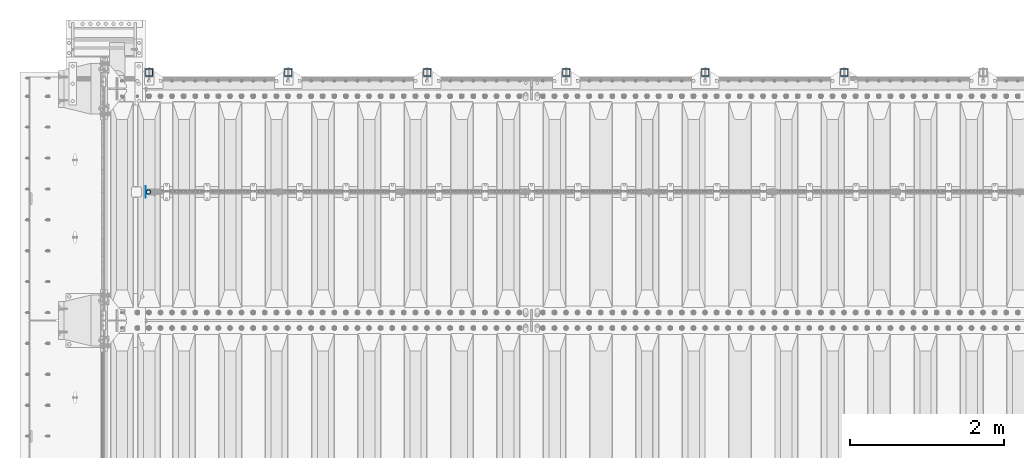
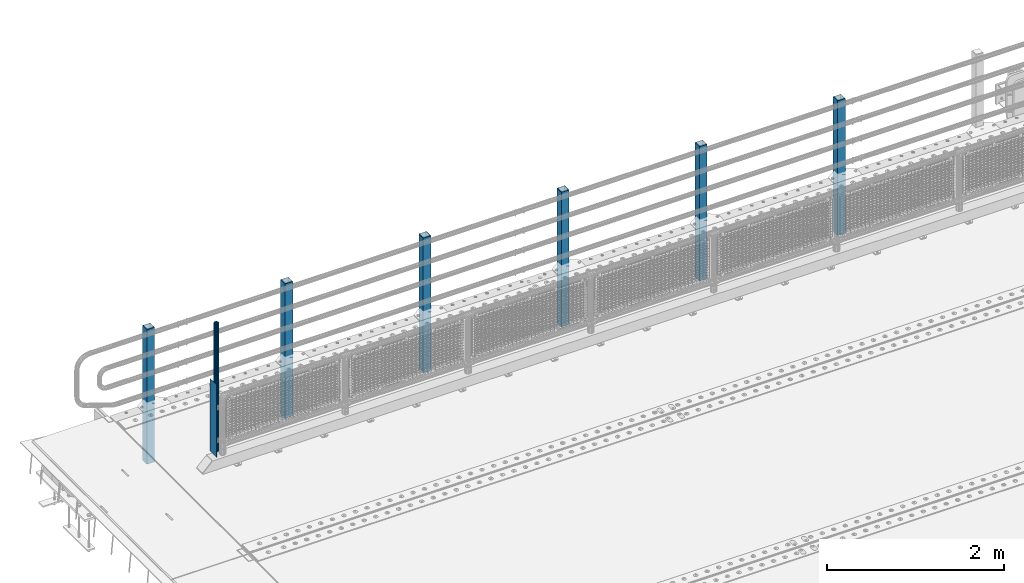
# One storey, part 63 of 247: 8 columns.
"""IFC2X3 building model written with IfcOpenShell, lengths in millimetres."""

from ifc_helpers import new_model, si_unit, frame, origin_with_axes, place, context, subcontext, project, spatial, faceted_brep, material, type_object, element, save


model = new_model("IFC2X3")

# Units and contexts
model_context = context("Model", 3, precision=1e-05, world=origin_with_axes())
body_context = subcontext(model_context, "Body", "Model", "MODEL_VIEW")
ifc_project = project(units=[si_unit("LENGTHUNIT", "METRE", prefix="MILLI"), si_unit("AREAUNIT", "SQUARE_METRE"), si_unit("VOLUMEUNIT", "CUBIC_METRE"), si_unit("MASSUNIT", "GRAM", prefix="KILO"), si_unit("TIMEUNIT", "SECOND"), si_unit("PLANEANGLEUNIT", "RADIAN"), si_unit("SOLIDANGLEUNIT", "STERADIAN"), si_unit("THERMODYNAMICTEMPERATUREUNIT", "DEGREE_CELSIUS"), si_unit("LUMINOUSINTENSITYUNIT", "LUMEN")], contexts=[model_context])

# Site, building, storey
site_placement = place(None, origin_with_axes())
site = spatial("IfcSite", under=ifc_project, at=site_placement, CompositionType="ELEMENT")
building_placement = place(site_placement, origin_with_axes())
building = spatial("IfcBuilding", under=site, at=building_placement, Name="Standard", CompositionType="ELEMENT")
storey_placement = place(building_placement, origin_with_axes())
storey = spatial("IfcBuildingStorey", under=building, at=storey_placement, Name="Undefined", CompositionType="ELEMENT", Elevation=0.0)

# Columns
ifc_material_1 = material(Name="Misc_Undefined")
column_type_1 = type_object("IfcColumnType", PredefinedType="NOTDEFINED")
column_1_placement = place(storey_placement, frame((541.0, 7664.5, 238.02), z_axis=(1.0, 0.0, 0.0), x_axis=(0.0, 0.0, 1.0)))
element("IfcColumn", 1, at=column_1_placement, inside=storey, type_object=column_type_1, material=ifc_material_1, context=body_context, shape_type="Brep", body=[
    faceted_brep([(0.0, -25.3500000000004, 0.0), (0.0, -23.4203461491616, 9.70102501045585), (1761.98, -23.4203461491616, 9.70102501045506), (1761.98, -25.3500000000004, 0.0), (0.0, -17.9251569030794, 17.9251569030785), (1761.98, -17.9251569030794, 17.925156903079), (0.0, -9.70102501045494, 23.4203461491616), (1761.98, -9.70102501045494, 23.4203461491611), (0.0, 0.0, 25.3500000000004), (1761.98, 0.0, 25.35), (0.0, 9.70102501045494, 23.4203461491616), (1761.98, 9.70102501045494, 23.4203461491611), (0.0, 17.9251569030794, 17.9251569030785), (1761.98, 17.9251569030794, 17.925156903079), (0.0, 23.4203461491616, 9.70102501045585), (1761.98, 23.4203461491616, 9.70102501045506), (0.0, 25.3500000000004, 0.0), (1761.98, 25.3500000000004, 0.0), (0.0, 23.4203461491616, -9.70102501045585), (1761.98, 23.4203461491616, -9.70102501045506), (0.0, 17.9251569030794, -17.9251569030785), (1761.98, 17.9251569030794, -17.925156903079), (0.0, 9.70102501045494, -23.4203461491616), (1761.98, 9.70102501045494, -23.4203461491611), (0.0, 0.0, -25.3500000000004), (1761.98, 0.0, -25.35), (0.0, -9.70102501045494, -23.4203461491616), (1761.98, -9.70102501045494, -23.4203461491611), (0.0, -17.9251569030794, -17.9251569030785), (1761.98, -17.9251569030794, -17.925156903079), (0.0, -23.4203461491616, -9.70102501045585), (1761.98, -23.4203461491616, -9.70102501045506), (0.0, -30.1499999999996, 0.0), (0.0, -27.8549679052148, -11.5379054858076), (1761.98, -27.8549679052148, -11.5379054858075), (1761.98, -30.1499999999996, 0.0), (0.0, -21.3192694527743, -21.3192694527752), (1761.98, -21.3192694527743, -21.3192694527744), (0.0, -11.5379054858076, -27.8549679052157), (1761.98, -11.5379054858076, -27.8549679052153), (0.0, 0.0, -30.1499999999996), (1761.98, 0.0, -30.15), (0.0, 11.5379054858076, -27.8549679052157), (1761.98, 11.5379054858076, -27.8549679052153), (0.0, 21.3192694527743, -21.3192694527752), (1761.98, 21.3192694527743, -21.3192694527744), (0.0, 27.8549679052157, -11.5379054858076), (1761.98, 27.8549679052157, -11.5379054858074), (0.0, 30.1499999999996, 0.0), (1761.98, 30.1499999999996, 0.0), (0.0, 27.8549679052157, 11.5379054858076), (1761.98, 27.8549679052157, 11.5379054858074), (0.0, 21.3192694527743, 21.3192694527752), (1761.98, 21.3192694527743, 21.3192694527744), (0.0, 11.5379054858076, 27.8549679052157), (1761.98, 11.5379054858076, 27.8549679052153), (0.0, 0.0, 30.1499999999996), (1761.98, 0.0, 30.15), (0.0, -11.5379054858076, 27.8549679052157), (1761.98, -11.5379054858076, 27.8549679052153), (0.0, -21.3192694527743, 21.3192694527752), (1761.98, -21.3192694527743, 21.3192694527744), (0.0, -27.8549679052157, 11.5379054858076), (1761.98, -27.8549679052157, 11.5379054858074)], [[[0, 1, 2, 3]], [[1, 4, 5, 2]], [[4, 6, 7, 5]], [[6, 8, 9, 7]], [[8, 10, 11, 9]], [[10, 12, 13, 11]], [[12, 14, 15, 13]], [[14, 16, 17, 15]], [[16, 18, 19, 17]], [[18, 20, 21, 19]], [[20, 22, 23, 21]], [[22, 24, 25, 23]], [[24, 26, 27, 25]], [[26, 28, 29, 27]], [[28, 30, 31, 29]], [[30, 0, 3, 31]], [[32, 33, 34, 35]], [[33, 36, 37, 34]], [[36, 38, 39, 37]], [[38, 40, 41, 39]], [[40, 42, 43, 41]], [[42, 44, 45, 43]], [[44, 46, 47, 45]], [[46, 48, 49, 47]], [[48, 50, 51, 49]], [[50, 52, 53, 51]], [[52, 54, 55, 53]], [[54, 56, 57, 55]], [[56, 58, 59, 57]], [[58, 60, 61, 59]], [[60, 62, 63, 61]], [[62, 32, 35, 63]], [[37, 39, 41, 43, 45, 47, 49, 51, 53, 55, 57, 59, 61, 63, 35, 34], [5, 7, 9, 11, 13, 15, 17, 19, 21, 23, 25, 27, 29, 31, 3, 2]], [[62, 60, 58, 56, 54, 52, 50, 48, 46, 44, 42, 40, 38, 36, 33, 32], [30, 28, 26, 24, 22, 20, 18, 16, 14, 12, 10, 8, 6, 4, 1, 0]]]),
])
ifc_material_2 = material()
column_type_2 = type_object("IfcColumnType", PredefinedType="NOTDEFINED")
for number, where, z_axis, x_axis in (
    (2, (9550.00000000013, 9210.00000000021, -844.999999999998), (0.0, -0.999999999999548, -9.5100000000016e-07), (0.0, 0.0, 1.0)),
    (3, (7750.00000000013, 9210.00000000021, -844.999999999998), (0.0, -0.999999999999548, -9.5100000000016e-07), (0.0, 0.0, 1.0)),
    (4, (5950.00000000013, 9210.00000000021, -844.999999999998), (0.0, -0.999999999999548, -9.5100000000016e-07), (0.0, 0.0, 1.0)),
    (5, (4150.00000000013, 9210.00000000021, -844.999999999998), (0.0, -0.999999999999548, -9.5100000000016e-07), (0.0, 0.0, 1.0)),
    (6, (2350.00000000013, 9210.00000000021, -844.999999999998), (0.0, -0.999999999999548, -9.5100000000016e-07), (0.0, 0.0, 1.0)),
    (7, (550.000000000131, 9210.00000000021, -844.999999999998), (0.0, -0.999999999999548, -9.5100000000016e-07), (0.0, 0.0, 1.0)),
):
    element("IfcColumn", number, at=place(storey_placement, frame(where, z_axis=z_axis, x_axis=x_axis)), inside=storey, type_object=column_type_2, material=ifc_material_2, context=body_context, shape_type="Brep", body=[
        faceted_brep([(0.0, 40.0, -40.0), (0.0, -40.0, -40.0), (1855.0, -40.0, -40.0), (1855.0, 40.0, -40.0), (0.0, -40.0, 40.0), (1855.0, -40.0, 40.0), (0.0, 40.0, 40.0), (1855.0, 40.0, 40.0), (0.0, 50.0, -50.0), (0.0, 50.0, 50.0), (1855.0, 50.0, 50.0), (1855.0, 50.0, -50.0), (0.0, -50.0, 50.0), (1855.0, -50.0, 50.0), (0.0, -50.0, -50.0), (1855.0, -50.0, -50.0)], [[[0, 1, 2, 3]], [[1, 4, 5, 2]], [[4, 6, 7, 5]], [[6, 0, 3, 7]], [[8, 9, 10, 11]], [[9, 12, 13, 10]], [[12, 14, 15, 13]], [[14, 8, 11, 15]], [[13, 15, 11, 10], [5, 7, 3, 2]], [[14, 12, 9, 8], [6, 4, 1, 0]]]),
    ])
column_type_3 = type_object("IfcColumnType", PredefinedType="NOTDEFINED")
column_2_placement = place(storey_placement, frame((504.5, 7664.5, 200.0), z_axis=(0.0, 1.0, 0.0), x_axis=(0.0, 0.0, 1.0)))
element("IfcColumn", 8, at=column_2_placement, inside=storey, type_object=column_type_3, material=ifc_material_1, context=body_context, shape_type="Brep", body=[
    faceted_brep([(0.0, 1.5, -75.0), (0.0, 1.5, 75.0), (1000.0, 1.5, 75.0), (1000.0, 1.5, -75.0), (0.0, -1.5, 75.0), (1000.0, -1.5, 75.0), (0.0, -1.5, -75.0), (1000.0, -1.5, -75.0)], [[[0, 1, 2, 3]], [[1, 4, 5, 2]], [[4, 6, 7, 5]], [[6, 0, 3, 7]], [[5, 7, 3, 2]], [[6, 4, 1, 0]]]),
])

save(model, "model.ifc")
